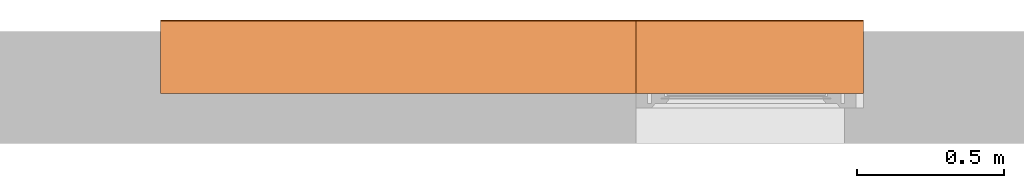
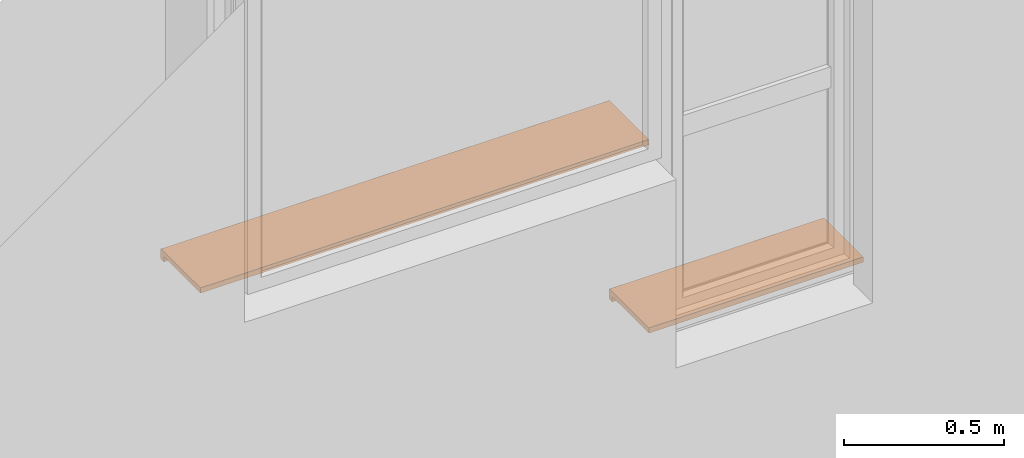
# One storey, part 4 of 4: 2 proxies.
"""IFC2X3 building model written with IfcOpenShell, lengths in millimetres."""

import ifcopenshell
import ifcopenshell.guid

model = None  # the IFC model being written
_history = None  # IfcOwnerHistory: only IFC2X3 demands one
_inside = {}  # id of a spatial element -> (the spatial element, [elements in it])
_under = {}  # id of a project, library or spatial element -> (it, [spatial elements below it])
_declared = {}  # id of a project -> (the project, [libraries it declares])
_typed = {}  # id of a type object -> (the type object, [elements of that type])
_made_of = {}  # id of a material, layer set ... -> (it, [elements and type objects made of it])


def new_model(schema):
    """Start an empty IFC model of exactly this schema.

    Asked for "IFC4X3", IfcOpenShell would pick the latest addendum, in which some entities
    have other attributes; the version numbers below select the first issue.
    IFC2X3 requires an IfcOwnerHistory on every rooted entity: one is made here for all.
    """
    global model, _history
    if schema == "IFC4X3":
        model = ifcopenshell.file(schema_version=(4, 3, 0, 0))
    else:
        model = ifcopenshell.file(schema=schema)
    _inside.clear()
    _under.clear()
    _declared.clear()
    _typed.clear()
    _made_of.clear()
    _history = None
    if model.schema == "IFC2X3":
        org = make("IfcOrganization", Name="unknown")
        user = make(
            "IfcPersonAndOrganization",
            ThePerson=make("IfcPerson", FamilyName="unknown"),
            TheOrganization=org,
        )
        app = make(
            "IfcApplication",
            ApplicationDeveloper=org,
            Version="unknown",
            ApplicationFullName="unknown",
            ApplicationIdentifier="unknown",
        )
        _history = make(
            "IfcOwnerHistory",
            OwningUser=user,
            OwningApplication=app,
            ChangeAction="ADDED",
            CreationDate=0,
        )
    return model


def make(cls, **values):
    """One entity of the class cls with the attributes given. An attribute that is None is left unset."""
    return model.create_entity(
        cls, **{name: value for name, value in values.items() if value is not None}
    )


def entity(cls, *values):
    """Any entity or typed value of the class cls, its attributes in the order of the schema. None: left unset."""
    e = model.create_entity(cls)
    for i, value in enumerate(values):
        if value is not None:
            e[i] = value
    return e


def rooted(cls, **values):
    """An entity with a GlobalId (a new one), such as an element, a storey or a relation."""
    return make(cls, GlobalId=ifcopenshell.guid.new(), OwnerHistory=_history, **values)


def si_unit(unit_type, name, prefix=None):
    """IfcSIUnit, for example si_unit("LENGTHUNIT", "METRE", prefix="MILLI")."""
    return make("IfcSIUnit", UnitType=unit_type, Prefix=prefix, Name=name)


def converted_unit(unit_type, name, factor, base, dimensions=None, offset=None):
    """IfcConversionBasedUnit, such as the inch: factor (a typed value) times the base unit."""
    return make(
        "IfcConversionBasedUnit"
        if offset is None
        else "IfcConversionBasedUnitWithOffset",
        ConversionOffset=offset,
        Dimensions=None
        if dimensions is None
        else entity("IfcDimensionalExponents", *dimensions),
        UnitType=unit_type,
        Name=name,
        ConversionFactor=make(
            "IfcMeasureWithUnit", ValueComponent=factor, UnitComponent=base
        ),
    )


def derived_unit(unit_type, elements):
    """IfcDerivedUnit: a product of units, each with its exponent."""
    return make(
        "IfcDerivedUnit",
        Elements=[
            make("IfcDerivedUnitElement", Unit=unit, Exponent=power)
            for unit, power in elements
        ],
        UnitType=unit_type,
    )


def assignment(units):
    """IfcUnitAssignment: the units of a project."""
    return None if units is None else make("IfcUnitAssignment", Units=units)


def point(xyz):
    """IfcCartesianPoint."""
    return None if xyz is None else make("IfcCartesianPoint", Coordinates=xyz)


def direction(xyz):
    """IfcDirection."""
    return None if xyz is None else make("IfcDirection", DirectionRatios=xyz)


def frame(location, z_axis=None, x_axis=None):
    """IfcAxis2Placement3D, a coordinate frame: its origin and axes. An axis left out is left unset."""
    return make(
        "IfcAxis2Placement3D",
        Location=point(location),
        Axis=direction(z_axis),
        RefDirection=direction(x_axis),
    )


def frame_2d(location, x_axis=None):
    """IfcAxis2Placement2D, a coordinate frame in the plane: its origin and x axis."""
    return make(
        "IfcAxis2Placement2D", Location=point(location), RefDirection=direction(x_axis)
    )


def origin():
    """The frame at (0, 0, 0) with its axes left unset."""
    return frame((0.0, 0.0, 0.0))


def place(relative_to, where):
    """IfcLocalPlacement: puts the frame where relative to a parent placement (None: the world)."""
    return make(
        "IfcLocalPlacement", PlacementRelTo=relative_to, RelativePlacement=where
    )


def context(
    kind, dimensions, precision=None, world=None, true_north=None, identifier=None
):
    """IfcGeometricRepresentationContext, for example the 3D "Model" context."""
    return make(
        "IfcGeometricRepresentationContext",
        ContextIdentifier=identifier,
        ContextType=kind,
        CoordinateSpaceDimension=dimensions,
        Precision=precision,
        WorldCoordinateSystem=world,
        TrueNorth=true_north,
    )


def subcontext(parent, identifier, kind, view, scale=None):
    """IfcGeometricRepresentationSubContext, for example "Body" below "Model"."""
    return make(
        "IfcGeometricRepresentationSubContext",
        ContextIdentifier=identifier,
        ContextType=kind,
        ParentContext=parent,
        TargetScale=scale,
        TargetView=view,
    )


def project(units=None, contexts=None):
    """IfcProject with its units and contexts."""
    return rooted(
        "IfcProject",
        Name="project",
        RepresentationContexts=contexts,
        UnitsInContext=assignment(units),
    )


def spatial(cls, under=None, at=None, **own):
    """A site, building, storey or space (cls), placed at a placement, below another one or the project."""
    s = rooted(cls, ObjectPlacement=at, **own)
    if under is not None:
        _under.setdefault(under.id(), (under, []))[1].append(s)
    return s


def polyline(points):
    """IfcPolyline through the points."""
    return make("IfcPolyline", Points=[point(p) for p in points])


def circle_curve(where, radius):
    """IfcCircle in the frame where."""
    return make("IfcCircle", Position=where, Radius=radius)


def parameter(value):
    """IfcParameterValue: where a trimmed curve begins or ends, as a parameter of its basis curve."""
    return model.create_entity("IfcParameterValue", value)


def trimmed(basis, trim1, trim2, sense, master):
    """IfcTrimmedCurve: the piece of a basis curve between two trims."""
    return make(
        "IfcTrimmedCurve",
        BasisCurve=basis,
        Trim1=trim1,
        Trim2=trim2,
        SenseAgreement=sense,
        MasterRepresentation=master,
    )


def segment(curve, same_sense, transition):
    """IfcCompositeCurveSegment."""
    return make(
        "IfcCompositeCurveSegment",
        Transition=transition,
        SameSense=same_sense,
        ParentCurve=curve,
    )


def composite_curve(segments, self_intersect=None):
    """IfcCompositeCurve: segments joined end to end."""
    return make("IfcCompositeCurve", Segments=segments, SelfIntersect=self_intersect)


def outline(outer, holes=None, kind="AREA"):
    """IfcArbitraryClosedProfileDef: a profile drawn as a closed curve; with holes, ...WithVoids."""
    if holes is None:
        return make("IfcArbitraryClosedProfileDef", ProfileType=kind, OuterCurve=outer)
    return make(
        "IfcArbitraryProfileDefWithVoids",
        ProfileType=kind,
        OuterCurve=outer,
        InnerCurves=holes,
    )


def extrude(swept, where, along, depth):
    """IfcExtrudedAreaSolid: the profile swept, set in the frame where, extruded along a direction by depth."""
    return make(
        "IfcExtrudedAreaSolid",
        SweptArea=swept,
        Position=where,
        ExtrudedDirection=direction(along),
        Depth=depth,
    )


def shape(context_of_items, identifier, shape_type, items):
    """IfcShapeRepresentation: the items that make up one representation, for example the "Body"."""
    return make(
        "IfcShapeRepresentation",
        ContextOfItems=context_of_items,
        RepresentationIdentifier=identifier,
        RepresentationType=shape_type,
        Items=items,
    )


def source(mapping_origin, context_of_items, identifier, shape_type, items):
    """IfcRepresentationMap: a shape defined once, which mapped items show again and again."""
    return make(
        "IfcRepresentationMap",
        MappingOrigin=mapping_origin,
        MappedRepresentation=shape(context_of_items, identifier, shape_type, items),
    )


def transform(
    local_origin,
    x_axis=None,
    y_axis=None,
    z_axis=None,
    scale=None,
    scale2=None,
    scale3=None,
    uniform=True,
):
    """IfcCartesianTransformationOperator3D, or its non-uniform kind. x_axis, y_axis, z_axis: its Axis1, 2, 3."""
    if uniform:
        return make(
            "IfcCartesianTransformationOperator3D",
            Axis1=direction(x_axis),
            Axis2=direction(y_axis),
            LocalOrigin=point(local_origin),
            Scale=scale,
            Axis3=direction(z_axis),
        )
    return make(
        "IfcCartesianTransformationOperator3DnonUniform",
        Axis1=direction(x_axis),
        Axis2=direction(y_axis),
        LocalOrigin=point(local_origin),
        Scale=scale,
        Axis3=direction(z_axis),
        Scale2=scale2,
        Scale3=scale3,
    )


def mapped(mapping_source, mapping_target):
    """IfcMappedItem: shows the shape of a source again, moved by a transform."""
    return make(
        "IfcMappedItem", MappingSource=mapping_source, MappingTarget=mapping_target
    )


def material(Name=None, Category=None):
    """IfcMaterial."""
    return make("IfcMaterial", Name=Name, Category=Category)


def made_of(thing, what):
    """Note that an element or type object is made of a material, layer set ...; save() writes the relation."""
    if what is not None:
        _made_of.setdefault(what.id(), (what, []))[1].append(thing)
    return thing


def type_object(cls, material=None, **own):
    """A type object (cls), such as IfcWallType, which elements share."""
    return made_of(rooted(cls, **own), material)


def type_shapes(of_type, sources):
    """Give a type object the sources (RepresentationMaps) that its elements show as mapped items."""
    of_type.RepresentationMaps = sources


def element(
    cls,
    number,
    at=None,
    inside=None,
    cuts=None,
    type_object=None,
    material=None,
    context=None,
    identifier="Body",
    shape_type=None,
    held_by="IfcProductDefinitionShape",
    body=None,
    shapes=None,
    **own,
):
    """One element of the class cls, such as IfcWall. Its Tag is "e" and its number.

    at: its placement. inside: the storey or other place that contains it. cuts: it is an
    opening in that element (IfcRelVoidsElement). A single representation is given by context,
    identifier, shape_type and body (its items); several are given by shapes. held_by: the class
    of the entity that holds the representations. save() writes the other relations.
    """
    e = rooted(cls, Tag="e%d" % number, ObjectPlacement=at, **own)
    if body is not None:
        shapes = [shape(context, identifier, shape_type, body)]
    if shapes is not None:
        e.Representation = make(held_by, Representations=shapes)
    if inside is not None:
        _inside.setdefault(inside.id(), (inside, []))[1].append(e)
    if cuts is not None:
        rooted(
            "IfcRelVoidsElement", RelatingBuildingElement=cuts, RelatedOpeningElement=e
        )
    if type_object is not None:
        _typed.setdefault(type_object.id(), (type_object, []))[1].append(e)
    return made_of(e, material)


def aggregate(whole, parts):
    """IfcRelAggregates: a whole, such as a stair, and the parts it consists of."""
    return rooted("IfcRelAggregates", RelatingObject=whole, RelatedObjects=parts)


def save(model, path):
    """Write the relations noted so far, then the file.

    IfcRelAggregates (storeys below a building ...), IfcRelContainedInSpatialStructure (elements
    in a storey), IfcRelDefinesByType, IfcRelAssociatesMaterial and IfcRelDeclares: one each for
    every whole, place, type object, material and project.
    """
    for whole, parts in _under.values():
        aggregate(whole, parts)
    for where, things in _inside.values():
        rooted(
            "IfcRelContainedInSpatialStructure",
            RelatedElements=things,
            RelatingStructure=where,
        )
    for kind, things in _typed.values():
        rooted("IfcRelDefinesByType", RelatedObjects=things, RelatingType=kind)
    for what, things in _made_of.values():
        rooted("IfcRelAssociatesMaterial", RelatedObjects=things, RelatingMaterial=what)
    for by, libraries in _declared.values():
        rooted("IfcRelDeclares", RelatingContext=by, RelatedDefinitions=libraries)
    model.write(path)


model = new_model("IFC2X3")

# Units and contexts
model_context = context("Model", 3, precision=0.01, world=origin(), true_north=direction((6.12303176911189e-17, 1.0)))
context_of_model = context(None, 3, precision=0.01, world=origin(), true_north=direction((6.12303176911189e-17, 1.0)))
body_context = subcontext(model_context, "Body", "Model", "MODEL_VIEW")
ifc_project = project(units=[si_unit("LENGTHUNIT", "METRE", prefix="MILLI"), si_unit("AREAUNIT", "SQUARE_METRE"), si_unit("VOLUMEUNIT", "CUBIC_METRE"), converted_unit("PLANEANGLEUNIT", "DEGREE", entity("IfcRatioMeasure", 0.0174532925199433), si_unit("PLANEANGLEUNIT", "RADIAN"), dimensions=[0, 0, 0, 0, 0, 0, 0]), si_unit("MASSUNIT", "GRAM", prefix="KILO"), si_unit("TIMEUNIT", "SECOND"), si_unit("FREQUENCYUNIT", "HERTZ"), si_unit("THERMODYNAMICTEMPERATUREUNIT", "DEGREE_CELSIUS"), derived_unit("THERMALTRANSMITTANCEUNIT", [(si_unit("MASSUNIT", "GRAM", prefix="KILO"), 1), (si_unit("THERMODYNAMICTEMPERATUREUNIT", "KELVIN"), -1), (si_unit("TIMEUNIT", "SECOND"), -3)]), derived_unit("VOLUMETRICFLOWRATEUNIT", [(si_unit("LENGTHUNIT", "METRE"), 3), (si_unit("TIMEUNIT", "SECOND"), -1)]), si_unit("ELECTRICCURRENTUNIT", "AMPERE"), si_unit("ELECTRICVOLTAGEUNIT", "VOLT"), si_unit("POWERUNIT", "WATT"), si_unit("FORCEUNIT", "NEWTON", prefix="KILO"), si_unit("ILLUMINANCEUNIT", "LUX"), si_unit("LUMINOUSFLUXUNIT", "LUMEN"), si_unit("LUMINOUSINTENSITYUNIT", "CANDELA"), si_unit("PRESSUREUNIT", "PASCAL")], contexts=[model_context, context_of_model])

# Site, building, storey
site_placement = place(None, origin())
site = spatial("IfcSite", under=ifc_project, at=site_placement, CompositionType="ELEMENT")
building_placement = place(site_placement, origin())
building = spatial("IfcBuilding", under=site, at=building_placement, CompositionType="ELEMENT")
storey_placement = place(building_placement, origin())
storey = spatial("IfcBuildingStorey", under=building, at=storey_placement, CompositionType="ELEMENT", Elevation=0.0)

# Proxies
ifc_material = material()
building_element_proxy_type_1 = type_object("IfcBuildingElementProxyType", PredefinedType="NOTDEFINED", material=ifc_material)
shared_shape_1 = source(origin(), body_context, "Body", "SweptSolid", [
    extrude(outline(composite_curve([segment(trimmed(circle_curve(frame_2d((-63.7499999999991, 15.0), x_axis=(1.0, 0.0)), 5.0), [parameter(89.9999999999997)], [parameter(179.999999999998)], True, "PARAMETER"), True, "CONTINUOUS"), segment(polyline([(-68.7499999999991, 15.0), (-68.7500000000002, -15.0)]), True, "CONTINUOUS"), segment(trimmed(circle_curve(frame_2d((-63.7499999999991, -15.0), x_axis=(1.0, 0.0)), 5.0), [parameter(179.999999999998)], [parameter(270.000000000003)], True, "PARAMETER"), True, "CONTINUOUS"), segment(polyline([(-63.7499999999989, -20.0), (-48.749999999999, -20.0)]), True, "CONTINUOUS"), segment(polyline([(-48.749999999999, -20.0), (-48.749999999999, 0.0)]), True, "CONTINUOUS"), segment(polyline([(-48.749999999999, 0.0), (181.249999999997, 0.0)]), True, "CONTINUOUS"), segment(polyline([(181.249999999997, 0.0), (181.249999999997, 20.0)]), True, "CONTINUOUS"), segment(polyline([(181.249999999997, 20.0), (-63.7499999999991, 20.0)]), True, "CONTINUOUS")], self_intersect=False)), frame((-810.0, -181.249999999996, 10.0), z_axis=(1.0, 0.0, 0.0), x_axis=(0.0, 1.0, 0.0)), (0.0, 0.0, 1.0), 1620.0),
])
type_shapes(building_element_proxy_type_1, [shared_shape_1])
proxy_1_placement = place(storey_placement, frame((-16194.3844562251, 12523.5585138251, 1540.0), z_axis=(0.0, 0.0, 1.0), x_axis=(-1.0, 0.0, 0.0)))
element("IfcBuildingElementProxy", 1, at=proxy_1_placement, inside=storey, type_object=building_element_proxy_type_1, material=ifc_material, context=body_context, shape_type="MappedRepresentation", body=[
    mapped(shared_shape_1, transform((0.0, 0.0, 0.0), scale=1.0)),
])
building_element_proxy_type_2 = type_object("IfcBuildingElementProxyType", PredefinedType="NOTDEFINED", material=ifc_material)
shared_shape_2 = source(origin(), body_context, "Body", "SweptSolid", [
    extrude(outline(composite_curve([segment(trimmed(circle_curve(frame_2d((-63.7499999999991, 15.0), x_axis=(1.0, 0.0)), 5.0), [parameter(89.9999999999997)], [parameter(179.999999999998)], True, "PARAMETER"), True, "CONTINUOUS"), segment(polyline([(-68.7499999999991, 15.0), (-68.7500000000002, -15.0)]), True, "CONTINUOUS"), segment(trimmed(circle_curve(frame_2d((-63.7499999999991, -15.0), x_axis=(1.0, 0.0)), 5.0), [parameter(179.999999999998)], [parameter(270.000000000003)], True, "PARAMETER"), True, "CONTINUOUS"), segment(polyline([(-63.7499999999989, -20.0), (-48.749999999999, -20.0)]), True, "CONTINUOUS"), segment(polyline([(-48.749999999999, -20.0), (-48.749999999999, 0.0)]), True, "CONTINUOUS"), segment(polyline([(-48.749999999999, 0.0), (181.249999999997, 0.0)]), True, "CONTINUOUS"), segment(polyline([(181.249999999997, 0.0), (181.249999999997, 20.0)]), True, "CONTINUOUS"), segment(polyline([(181.249999999997, 20.0), (-63.7499999999991, 20.0)]), True, "CONTINUOUS")], self_intersect=False)), frame((-387.5, -181.249999999997, 10.0), z_axis=(1.0, 0.0, 0.0), x_axis=(0.0, 1.0, 0.0)), (0.0, 0.0, 1.0), 775.0),
])
type_shapes(building_element_proxy_type_2, [shared_shape_2])
proxy_2_placement = place(storey_placement, frame((-14996.8844562251, 12523.5585138251, 820.0), z_axis=(0.0, 0.0, 1.0), x_axis=(-1.0, 0.0, 0.0)))
element("IfcBuildingElementProxy", 2, at=proxy_2_placement, inside=storey, type_object=building_element_proxy_type_2, material=ifc_material, context=body_context, shape_type="MappedRepresentation", body=[
    mapped(shared_shape_2, transform((0.0, 0.0, 0.0), scale=1.0)),
])

save(model, "model.ifc")
